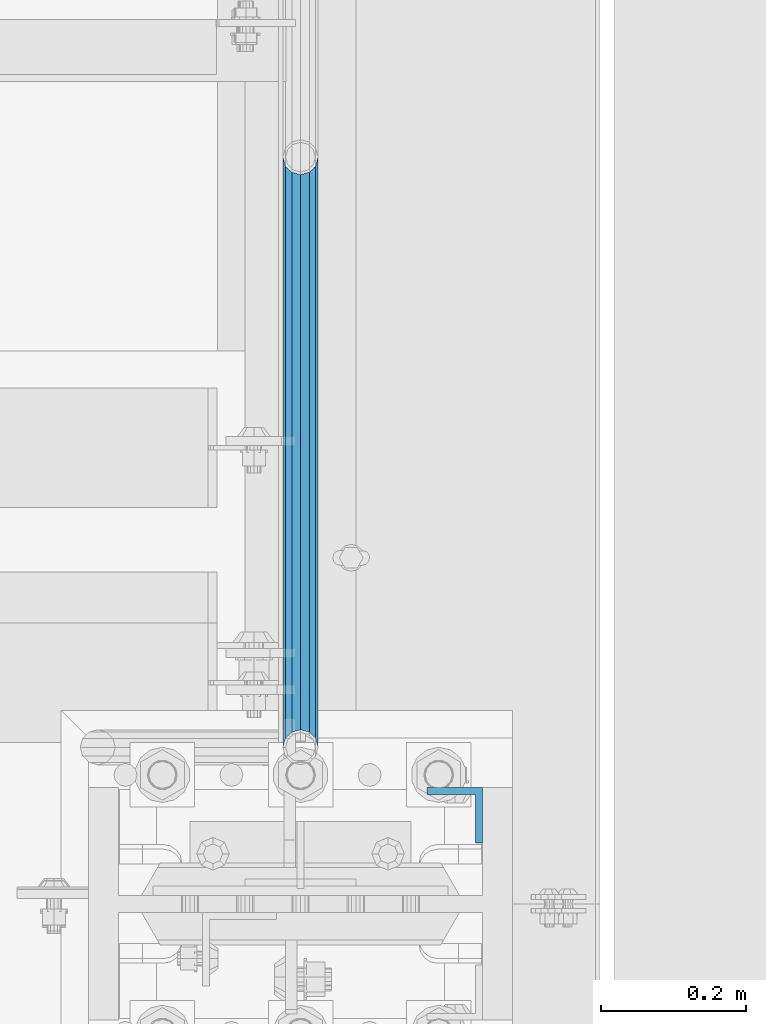
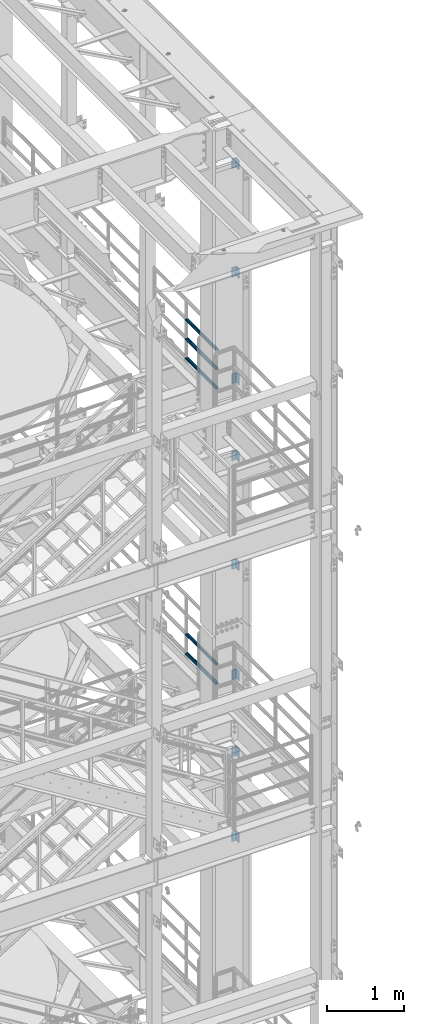
# One storey, part 1218 of 1876: 13 beams, 4 elements without a shape of their own.
"""IFC2X3 building model written with IfcOpenShell, lengths in millimetres."""

from ifc_helpers import new_model, si_unit, frame, origin_with_axes, place, context, subcontext, project, spatial, faceted_brep, material, type_object, element, aggregate, save


model = new_model("IFC2X3")

# Units and contexts
model_context = context("Model", 3, precision=1e-05, world=origin_with_axes())
body_context = subcontext(model_context, "Body", "Model", "MODEL_VIEW")
ifc_project = project(units=[si_unit("LENGTHUNIT", "METRE", prefix="MILLI"), si_unit("AREAUNIT", "SQUARE_METRE"), si_unit("VOLUMEUNIT", "CUBIC_METRE"), si_unit("MASSUNIT", "GRAM", prefix="KILO"), si_unit("TIMEUNIT", "SECOND"), si_unit("PLANEANGLEUNIT", "RADIAN"), si_unit("SOLIDANGLEUNIT", "STERADIAN"), si_unit("THERMODYNAMICTEMPERATUREUNIT", "DEGREE_CELSIUS"), si_unit("LUMINOUSINTENSITYUNIT", "LUMEN")], contexts=[model_context])

# Site, building, storey
site_placement = place(None, origin_with_axes())
site = spatial("IfcSite", under=ifc_project, at=site_placement, CompositionType="ELEMENT")
building_placement = place(site_placement, origin_with_axes())
building = spatial("IfcBuilding", under=site, at=building_placement, Name="Undefined", CompositionType="ELEMENT")
storey_placement = place(building_placement, origin_with_axes())
storey = spatial("IfcBuildingStorey", under=building, at=storey_placement, Name="Undefined", CompositionType="ELEMENT", Elevation=0.0)

# Assembly, beams
assembly_1_placement = place(storey_placement, origin_with_axes())
assembly_1 = element("IfcElementAssembly", 1, at=assembly_1_placement, inside=storey, Name="RAIL", AssemblyPlace="NOTDEFINED", PredefinedType="RIGID_FRAME")
ifc_material_1 = material()
beam_type_1 = type_object("IfcBeamType", Name="PIPE1-1/2SCH40", PredefinedType="NOTDEFINED")
beam_1_placement = place(assembly_1_placement, frame((7620.00000000001, -3542.7031, 18145.125), z_axis=(0.0, 0.0, 1.0), x_axis=(0.0, -1.0, 0.0)))
beam_1 = element("IfcBeam", 2, at=beam_1_placement, type_object=beam_type_1, material=ifc_material_1, Name="RAIL", ObjectType="PIPE1-1/2SCH40", context=body_context, shape_type="Brep", body=[
    faceted_brep([(792.499707006684, -12.0649999999996, 20.8971929933177), (792.499707006684, -12.0650000000314, 15.8661214311469), (792.006278568813, -10.2235000000001, 17.7076214311819), (789.266900000001, -9.09494701772928e-13, 20.4470000000001), (789.266900000001, -9.09494701772928e-13, 24.130000000001), (792.00627856883, 10.2235000000001, 17.7076214311819), (792.499707006684, 12.0649999999678, 15.8661214312124), (792.499707006684, 12.0649999999996, 20.8971929933177), (813.396900000002, 24.1300000000001, 0.0), (801.331900000001, 20.8971929933186, 12.0649999999987), (801.331900000001, 20.8971929933186, -12.0649999999987), (798.142328437896, 17.7076214311801, 10.2235000000001), (800.881707006714, 20.4470000000001, 0.0), (798.142328437896, 17.7076214311801, -10.2235000000001), (792.499707006684, 12.0649999999678, -15.8661214312124), (792.499707006684, 12.0649999999996, -20.8971929933177), (792.00627856883, 10.2235000000001, -17.7076214311819), (789.266900000001, 0.0, -20.4470000000001), (789.266900000001, 0.0, -24.130000000001), (792.499707006684, -12.0650000000314, -15.8661214311469), (792.499707006684, -12.0649999999996, -20.8971929933177), (792.006278568813, -10.2235000000001, -17.7076214311819), (813.396900000002, -24.1300000000319, 0.0), (801.331900000001, -20.8971929933186, -12.0649999999987), (801.331900000001, -20.8971929933186, 12.0649999999987), (798.142328437831, -17.7076214311801, -10.2235000000001), (800.881707006651, -20.4470000000001, 0.0), (798.142328437831, -17.7076214311801, 10.2235000000001), (12.0650000000064, -20.8971929933177, -12.0649999999987), (20.8971929933249, -12.0650000000005, -20.8971929933177), (0.0, 24.1299999999992, 0.0), (12.0650000000064, 20.8971929933177, -12.0649999999987), (12.0650000000064, 20.8971929933177, 12.0649999999987), (20.8971929933249, 12.0650000000005, 20.8971929933177), (24.1300000000064, 0.0, 24.130000000001), (20.8971929933249, 12.0650000000005, -20.8971929933177), (24.1300000000063, 0.0, -24.130000000001), (24.1300000000063, 0.0, -20.4470000000001), (20.8971929933249, -12.0650000000005, -15.8661214311796), (21.3906214311868, -10.2235000000001, -17.7076214311819), (21.3906214311868, 10.2235000000001, -17.7076214311819), (20.8971929933249, 12.0650000000005, -15.8661214311796), (15.2545715621445, 17.7076214311801, -10.2235000000001), (12.5151929933249, 20.4470000000001, 0.0), (15.2545715621445, 17.7076214311801, 10.2235000000001), (20.8971929933249, 12.0650000000005, 15.8661214311796), (21.3906214311868, 10.2235000000001, 17.7076214311819), (24.1300000000064, 0.0, 20.4470000000001), (21.3906214311868, -10.2235000000001, 17.7076214311819), (20.8971929933249, -12.0650000000005, 15.8661214311796), (20.8971929933249, -12.0650000000005, 20.8971929933177), (12.0650000000064, -20.8971929933177, 12.0649999999987), (0.0, -24.1299999999992, 0.0), (15.2545715621445, -17.7076214311801, 10.2235000000001), (12.5151929933249, -20.4470000000001, 0.0), (15.2545715621445, -17.7076214311801, -10.2235000000001)], [[[0, 1, 2, 3, 4]], [[4, 3, 5, 6, 7]], [[8, 9, 10]], [[7, 6, 11, 12, 13, 14, 15, 10, 9]], [[16, 17, 18, 15, 14]], [[19, 20, 18, 17, 21]], [[22, 23, 24]], [[24, 23, 20, 19, 25, 26, 27, 1, 0]], [[28, 29, 20, 23]], [[30, 31, 32]], [[33, 34, 4, 7]], [[32, 33, 7, 9]], [[30, 32, 9, 8]], [[31, 30, 8, 10]], [[35, 31, 10, 15]], [[36, 35, 15, 18]], [[29, 36, 18, 20]], [[37, 36, 29, 38, 39]], [[40, 41, 35, 36, 37]], [[32, 31, 35, 41, 42, 43, 44, 45, 33]], [[33, 45, 46, 47, 34]], [[34, 47, 48, 49, 50]], [[34, 50, 0, 4]], [[50, 51, 24, 0]], [[51, 52, 22, 24]], [[52, 28, 23, 22]], [[51, 28, 52]], [[50, 49, 53, 54, 55, 38, 29, 28, 51]], [[55, 54, 26, 25]], [[21, 39, 38, 55, 25, 19]], [[37, 39, 21, 17]], [[40, 37, 17, 16]], [[42, 41, 40, 16, 14, 13]], [[43, 42, 13, 12]], [[44, 43, 12, 11]], [[5, 46, 45, 44, 11, 6]], [[47, 46, 5, 3]], [[48, 47, 3, 2]], [[53, 49, 48, 2, 1, 27]], [[54, 53, 27, 26]]]),
])
beam_2_placement = place(assembly_1_placement, frame((7620.00000000001, -4356.1, 18449.925000036), z_axis=(0.0, 0.0, -1.0), x_axis=(0.0, 1.0, 0.0)))
beam_2 = element("IfcBeam", 3, at=beam_2_placement, type_object=beam_type_1, material=ifc_material_1, Name="RAIL", ObjectType="PIPE1-1/2SCH40", context=body_context, shape_type="Brep", body=[
    faceted_brep([(0.0, 24.1299999999992, 0.0), (12.0650000000064, 20.8971929933177, -12.0649999999987), (12.0650000000064, 20.8971929933177, 12.0649999999987), (12.0650000000064, -20.8971929933177, 12.0649999999987), (12.0650000000064, -20.8971929933177, -12.0649999999987), (0.0, -24.1299999999992, 0.0), (20.8971929933249, -12.0650000000005, 20.8971929933177), (20.8971929933249, -12.0650000000005, 15.8661214311796), (15.2545715621445, -17.7076214311801, 10.2235000000001), (12.5151929933249, -20.4470000000001, 0.0), (15.2545715621445, -17.7076214311801, -10.2235000000001), (20.8971929933249, -12.0650000000005, -15.8661214311796), (20.8971929933249, -12.0650000000005, -20.8971929933177), (24.1300000000063, 0.0, -20.4470000000001), (24.1300000000063, 0.0, -24.130000000001), (21.3906214311868, -10.2235000000001, -17.7076214311819), (21.3906214311868, 10.2235000000001, -17.7076214311819), (20.8971929933249, 12.0650000000005, -15.8661214311796), (20.8971929933249, 12.0650000000005, -20.8971929933177), (15.2545715621445, 17.7076214311801, -10.2235000000001), (12.5151929933249, 20.4470000000001, 0.0), (15.2545715621445, 17.7076214311801, 10.2235000000001), (20.8971929933249, 12.0650000000005, 15.8661214311796), (20.8971929933249, 12.0650000000005, 20.8971929933177), (21.3906214311868, 10.2235000000001, 17.7076214311819), (24.1300000000064, 0.0, 20.4470000000001), (24.1300000000064, 0.0, 24.130000000001), (21.3906214311868, -10.2235000000001, 17.7076214311819), (813.396900000002, 24.1300000000001, 0.0), (801.331900000001, 20.8971929933186, -12.0649999999987), (792.499707006684, 12.0649999999996, -20.8971929933177), (813.396900000002, -24.1300000000319, 0.0), (801.331900000001, -20.8971929933186, -12.0649999999987), (801.331900000001, -20.8971929933186, 12.0649999999987), (792.499707006684, -12.0649999999996, 20.8971929933177), (792.499707006684, -12.0649999999996, -20.8971929933177), (789.266900000001, 0.0, -24.130000000001), (792.00627856883, 10.2235000000001, -17.7076214311819), (789.266900000001, 0.0, -20.4470000000001), (792.499707006684, 12.0649999999678, -15.8661214312124), (792.499707006684, -12.0650000000314, -15.8661214311469), (792.006278568813, -10.2235000000001, -17.7076214311819), (798.142328437831, -17.7076214311801, -10.2235000000001), (800.881707006651, -20.4470000000001, 0.0), (798.142328437831, -17.7076214311801, 10.2235000000001), (792.499707006684, -12.0650000000314, 15.8661214311469), (792.006278568813, -10.2235000000001, 17.7076214311819), (789.266900000001, -9.09494701772928e-13, 20.4470000000001), (789.266900000001, -9.09494701772928e-13, 24.130000000001), (792.499707006684, 12.0649999999996, 20.8971929933177), (801.331900000001, 20.8971929933186, 12.0649999999987), (792.499707006684, 12.0649999999678, 15.8661214312124), (798.142328437896, 17.7076214311801, 10.2235000000001), (800.881707006714, 20.4470000000001, 0.0), (798.142328437896, 17.7076214311801, -10.2235000000001), (792.00627856883, 10.2235000000001, 17.7076214311819)], [[[0, 1, 2]], [[3, 4, 5]], [[6, 7, 8, 9, 10, 11, 12, 4, 3]], [[13, 14, 12, 11, 15]], [[16, 17, 18, 14, 13]], [[2, 1, 18, 17, 19, 20, 21, 22, 23]], [[23, 22, 24, 25, 26]], [[26, 25, 27, 7, 6]], [[1, 0, 28, 29]], [[18, 1, 29, 30]], [[31, 32, 33]], [[6, 3, 33, 34]], [[3, 5, 31, 33]], [[5, 4, 32, 31]], [[4, 12, 35, 32]], [[12, 14, 36, 35]], [[14, 18, 30, 36]], [[37, 38, 36, 30, 39]], [[40, 35, 36, 38, 41]], [[33, 32, 35, 40, 42, 43, 44, 45, 34]], [[34, 45, 46, 47, 48]], [[26, 6, 34, 48]], [[2, 23, 49, 50]], [[23, 26, 48, 49]], [[0, 2, 50, 28]], [[28, 50, 29]], [[49, 51, 52, 53, 54, 39, 30, 29, 50]], [[48, 47, 55, 51, 49]], [[25, 24, 55, 47]], [[55, 24, 22, 21, 52, 51]], [[21, 20, 53, 52]], [[20, 19, 54, 53]], [[19, 17, 16, 37, 39, 54]], [[16, 13, 38, 37]], [[13, 15, 41, 38]], [[41, 15, 11, 10, 42, 40]], [[10, 9, 43, 42]], [[9, 8, 44, 43]], [[8, 7, 27, 46, 45, 44]], [[27, 25, 47, 46]]]),
])
beam_3_placement = place(assembly_1_placement, frame((7620.00000000001, -4356.1, 18754.7250000359), z_axis=(0.0, 0.0, -1.0), x_axis=(0.0, 1.0, 0.0)))
beam_3 = element("IfcBeam", 4, at=beam_3_placement, type_object=beam_type_1, material=ifc_material_1, Name="RAIL", ObjectType="PIPE1-1/2SCH40", context=body_context, shape_type="Brep", body=[
    faceted_brep([(0.0, 24.1299999999992, 0.0), (12.0650000000064, 20.8971929933177, -12.0649999999987), (12.0650000000064, 20.8971929933177, 12.0649999999987), (12.0650000000064, -20.8971929933177, 12.0649999999987), (12.0650000000064, -20.8971929933177, -12.0649999999987), (0.0, -24.1299999999992, 0.0), (20.8971929933249, -12.0650000000005, 20.8971929933177), (20.8971929933249, -12.0650000000005, 15.8661214311796), (15.2545715621445, -17.7076214311801, 10.2235000000001), (12.5151929933249, -20.4470000000001, 0.0), (15.2545715621445, -17.7076214311801, -10.2235000000001), (20.8971929933249, -12.0650000000005, -15.8661214311796), (20.8971929933249, -12.0650000000005, -20.8971929933177), (24.1300000000063, 0.0, -20.4470000000001), (24.1300000000063, 0.0, -24.130000000001), (21.3906214311868, -10.2235000000001, -17.7076214311819), (21.3906214311868, 10.2235000000001, -17.7076214311819), (20.8971929933249, 12.0650000000005, -15.8661214311796), (20.8971929933249, 12.0650000000005, -20.8971929933177), (15.2545715621445, 17.7076214311801, -10.2235000000001), (12.5151929933249, 20.4470000000001, 0.0), (15.2545715621445, 17.7076214311801, 10.2235000000001), (20.8971929933249, 12.0650000000005, 15.8661214311796), (20.8971929933249, 12.0650000000005, 20.8971929933177), (21.3906214311868, 10.2235000000001, 17.7076214311819), (24.1300000000064, 0.0, 20.4470000000001), (24.1300000000064, 0.0, 24.130000000001), (21.3906214311868, -10.2235000000001, 17.7076214311819), (813.396900000002, 24.1300000000001, 0.0), (801.331900000001, 20.8971929933186, -12.0649999999987), (792.499707006684, 12.0649999999996, -20.8971929933177), (813.396900000002, -24.1300000000319, 0.0), (801.331900000001, -20.8971929933186, -12.0649999999987), (801.331900000001, -20.8971929933186, 12.0649999999987), (792.499707006684, -12.0649999999996, 20.8971929933177), (792.499707006684, -12.0649999999996, -20.8971929933177), (789.266900000001, 0.0, -24.130000000001), (792.00627856883, 10.2235000000001, -17.7076214311819), (789.266900000001, 0.0, -20.4470000000001), (792.499707006684, 12.0649999999678, -15.8661214312124), (792.499707006684, -12.0650000000314, -15.8661214311469), (792.006278568813, -10.2235000000001, -17.7076214311819), (798.142328437831, -17.7076214311801, -10.2235000000001), (800.881707006651, -20.4470000000001, 0.0), (798.142328437831, -17.7076214311801, 10.2235000000001), (792.499707006684, -12.0650000000314, 15.8661214311469), (792.006278568813, -10.2235000000001, 17.7076214311819), (789.266900000001, -9.09494701772928e-13, 20.4470000000001), (789.266900000001, -9.09494701772928e-13, 24.130000000001), (792.499707006684, 12.0649999999996, 20.8971929933177), (801.331900000001, 20.8971929933186, 12.0649999999987), (792.499707006684, 12.0649999999678, 15.8661214312124), (798.142328437896, 17.7076214311801, 10.2235000000001), (800.881707006714, 20.4470000000001, 0.0), (798.142328437896, 17.7076214311801, -10.2235000000001), (792.00627856883, 10.2235000000001, 17.7076214311819)], [[[0, 1, 2]], [[3, 4, 5]], [[6, 7, 8, 9, 10, 11, 12, 4, 3]], [[13, 14, 12, 11, 15]], [[16, 17, 18, 14, 13]], [[2, 1, 18, 17, 19, 20, 21, 22, 23]], [[23, 22, 24, 25, 26]], [[26, 25, 27, 7, 6]], [[1, 0, 28, 29]], [[18, 1, 29, 30]], [[31, 32, 33]], [[6, 3, 33, 34]], [[3, 5, 31, 33]], [[5, 4, 32, 31]], [[4, 12, 35, 32]], [[12, 14, 36, 35]], [[14, 18, 30, 36]], [[37, 38, 36, 30, 39]], [[40, 35, 36, 38, 41]], [[33, 32, 35, 40, 42, 43, 44, 45, 34]], [[34, 45, 46, 47, 48]], [[26, 6, 34, 48]], [[2, 23, 49, 50]], [[23, 26, 48, 49]], [[0, 2, 50, 28]], [[28, 50, 29]], [[49, 51, 52, 53, 54, 39, 30, 29, 50]], [[48, 47, 55, 51, 49]], [[25, 24, 55, 47]], [[55, 24, 22, 21, 52, 51]], [[21, 20, 53, 52]], [[20, 19, 54, 53]], [[19, 17, 16, 37, 39, 54]], [[16, 13, 38, 37]], [[13, 15, 41, 38]], [[41, 15, 11, 10, 42, 40]], [[10, 9, 43, 42]], [[9, 8, 44, 43]], [[8, 7, 27, 46, 45, 44]], [[27, 25, 47, 46]]]),
])
aggregate(assembly_1, [beam_1, beam_2, beam_3])

assembly_2_placement = place(storey_placement, origin_with_axes())
assembly_2 = element("IfcElementAssembly", 5, at=assembly_2_placement, inside=storey, Name="RAIL", AssemblyPlace="NOTDEFINED", PredefinedType="RIGID_FRAME")
beam_4_placement = place(assembly_2_placement, frame((7620.00000000001, -3542.7031, 13471.525), z_axis=(0.0, 0.0, 1.0), x_axis=(0.0, -1.0, 0.0)))
beam_4 = element("IfcBeam", 6, at=beam_4_placement, type_object=beam_type_1, material=ifc_material_1, Name="RAIL", ObjectType="PIPE1-1/2SCH40", context=body_context, shape_type="Brep", body=[
    faceted_brep([(792.499707006684, -12.0649999999996, 20.8971929933177), (792.499707006684, -12.0650000000314, 15.8661214311469), (792.006278568813, -10.2235000000001, 17.7076214311819), (789.266900000001, -9.09494701772928e-13, 20.4470000000001), (789.266900000001, -9.09494701772928e-13, 24.130000000001), (792.00627856883, 10.2235000000001, 17.7076214311819), (792.499707006684, 12.0649999999678, 15.8661214312124), (792.499707006684, 12.0649999999996, 20.8971929933177), (813.396900000002, 24.1300000000001, 0.0), (801.331900000001, 20.8971929933186, 12.0649999999987), (801.331900000001, 20.8971929933186, -12.0649999999987), (798.142328437896, 17.7076214311801, 10.2235000000001), (800.881707006714, 20.4470000000001, 0.0), (798.142328437896, 17.7076214311801, -10.2235000000001), (792.499707006684, 12.0649999999678, -15.8661214312124), (792.499707006684, 12.0649999999996, -20.8971929933177), (792.00627856883, 10.2235000000001, -17.7076214311819), (789.266900000001, 0.0, -20.4470000000001), (789.266900000001, 0.0, -24.130000000001), (792.499707006684, -12.0650000000314, -15.8661214311469), (792.499707006684, -12.0649999999996, -20.8971929933177), (792.006278568813, -10.2235000000001, -17.7076214311819), (813.396900000002, -24.1300000000319, 0.0), (801.331900000001, -20.8971929933186, -12.0649999999987), (801.331900000001, -20.8971929933186, 12.0649999999987), (798.142328437831, -17.7076214311801, -10.2235000000001), (800.881707006651, -20.4470000000001, 0.0), (798.142328437831, -17.7076214311801, 10.2235000000001), (12.0650000000064, -20.8971929933177, -12.0649999999987), (20.8971929933249, -12.0650000000005, -20.8971929933177), (0.0, 24.1299999999992, 0.0), (12.0650000000064, 20.8971929933177, -12.0649999999987), (12.0650000000064, 20.8971929933177, 12.0649999999987), (20.8971929933249, 12.0650000000005, 20.8971929933177), (24.1300000000064, 0.0, 24.130000000001), (20.8971929933249, 12.0650000000005, -20.8971929933177), (24.1300000000063, 0.0, -24.130000000001), (24.1300000000063, 0.0, -20.4470000000001), (20.8971929933249, -12.0650000000005, -15.8661214311796), (21.3906214311868, -10.2235000000001, -17.7076214311819), (21.3906214311868, 10.2235000000001, -17.7076214311819), (20.8971929933249, 12.0650000000005, -15.8661214311796), (15.2545715621445, 17.7076214311801, -10.2235000000001), (12.5151929933249, 20.4470000000001, 0.0), (15.2545715621445, 17.7076214311801, 10.2235000000001), (20.8971929933249, 12.0650000000005, 15.8661214311796), (21.3906214311868, 10.2235000000001, 17.7076214311819), (24.1300000000064, 0.0, 20.4470000000001), (21.3906214311868, -10.2235000000001, 17.7076214311819), (20.8971929933249, -12.0650000000005, 15.8661214311796), (20.8971929933249, -12.0650000000005, 20.8971929933177), (12.0650000000064, -20.8971929933177, 12.0649999999987), (0.0, -24.1299999999992, 0.0), (15.2545715621445, -17.7076214311801, 10.2235000000001), (12.5151929933249, -20.4470000000001, 0.0), (15.2545715621445, -17.7076214311801, -10.2235000000001)], [[[0, 1, 2, 3, 4]], [[4, 3, 5, 6, 7]], [[8, 9, 10]], [[7, 6, 11, 12, 13, 14, 15, 10, 9]], [[16, 17, 18, 15, 14]], [[19, 20, 18, 17, 21]], [[22, 23, 24]], [[24, 23, 20, 19, 25, 26, 27, 1, 0]], [[28, 29, 20, 23]], [[30, 31, 32]], [[33, 34, 4, 7]], [[32, 33, 7, 9]], [[30, 32, 9, 8]], [[31, 30, 8, 10]], [[35, 31, 10, 15]], [[36, 35, 15, 18]], [[29, 36, 18, 20]], [[37, 36, 29, 38, 39]], [[40, 41, 35, 36, 37]], [[32, 31, 35, 41, 42, 43, 44, 45, 33]], [[33, 45, 46, 47, 34]], [[34, 47, 48, 49, 50]], [[34, 50, 0, 4]], [[50, 51, 24, 0]], [[51, 52, 22, 24]], [[52, 28, 23, 22]], [[51, 28, 52]], [[50, 49, 53, 54, 55, 38, 29, 28, 51]], [[55, 54, 26, 25]], [[21, 39, 38, 55, 25, 19]], [[37, 39, 21, 17]], [[40, 37, 17, 16]], [[42, 41, 40, 16, 14, 13]], [[43, 42, 13, 12]], [[44, 43, 12, 11]], [[5, 46, 45, 44, 11, 6]], [[47, 46, 5, 3]], [[48, 47, 3, 2]], [[53, 49, 48, 2, 1, 27]], [[54, 53, 27, 26]]]),
])
beam_5_placement = place(assembly_2_placement, frame((7620.00000000001, -4356.1, 13776.325000036), z_axis=(0.0, 0.0, -1.0), x_axis=(0.0, 1.0, 0.0)))
beam_5 = element("IfcBeam", 7, at=beam_5_placement, type_object=beam_type_1, material=ifc_material_1, Name="RAIL", ObjectType="PIPE1-1/2SCH40", context=body_context, shape_type="Brep", body=[
    faceted_brep([(0.0, 24.1299999999992, 0.0), (12.0650000000064, 20.8971929933177, -12.0649999999987), (12.0650000000064, 20.8971929933177, 12.0649999999987), (12.0650000000064, -20.8971929933177, 12.0649999999987), (12.0650000000064, -20.8971929933177, -12.0649999999987), (0.0, -24.1299999999992, 0.0), (20.8971929933249, -12.0650000000005, 20.8971929933177), (20.8971929933249, -12.0650000000005, 15.8661214311796), (15.2545715621445, -17.7076214311801, 10.2235000000001), (12.5151929933249, -20.4470000000001, 0.0), (15.2545715621445, -17.7076214311801, -10.2235000000001), (20.8971929933249, -12.0650000000005, -15.8661214311796), (20.8971929933249, -12.0650000000005, -20.8971929933177), (24.1300000000063, 0.0, -20.4470000000001), (24.1300000000063, 0.0, -24.130000000001), (21.3906214311868, -10.2235000000001, -17.7076214311819), (21.3906214311868, 10.2235000000001, -17.7076214311819), (20.8971929933249, 12.0650000000005, -15.8661214311796), (20.8971929933249, 12.0650000000005, -20.8971929933177), (15.2545715621445, 17.7076214311801, -10.2235000000001), (12.5151929933249, 20.4470000000001, 0.0), (15.2545715621445, 17.7076214311801, 10.2235000000001), (20.8971929933249, 12.0650000000005, 15.8661214311796), (20.8971929933249, 12.0650000000005, 20.8971929933177), (21.3906214311868, 10.2235000000001, 17.7076214311819), (24.1300000000064, 0.0, 20.4470000000001), (24.1300000000064, 0.0, 24.130000000001), (21.3906214311868, -10.2235000000001, 17.7076214311819), (813.396900000002, 24.1300000000001, 0.0), (801.331900000001, 20.8971929933186, -12.0649999999987), (792.499707006684, 12.0649999999996, -20.8971929933177), (813.396900000002, -24.1300000000319, 0.0), (801.331900000001, -20.8971929933186, -12.0649999999987), (801.331900000001, -20.8971929933186, 12.0649999999987), (792.499707006684, -12.0649999999996, 20.8971929933177), (792.499707006684, -12.0649999999996, -20.8971929933177), (789.266900000001, 0.0, -24.130000000001), (792.00627856883, 10.2235000000001, -17.7076214311819), (789.266900000001, 0.0, -20.4470000000001), (792.499707006684, 12.0649999999678, -15.8661214312124), (792.499707006684, -12.0650000000314, -15.8661214311469), (792.006278568813, -10.2235000000001, -17.7076214311819), (798.142328437831, -17.7076214311801, -10.2235000000001), (800.881707006651, -20.4470000000001, 0.0), (798.142328437831, -17.7076214311801, 10.2235000000001), (792.499707006684, -12.0650000000314, 15.8661214311469), (792.006278568813, -10.2235000000001, 17.7076214311819), (789.266900000001, -9.09494701772928e-13, 20.4470000000001), (789.266900000001, -9.09494701772928e-13, 24.130000000001), (792.499707006684, 12.0649999999996, 20.8971929933177), (801.331900000001, 20.8971929933186, 12.0649999999987), (792.499707006684, 12.0649999999678, 15.8661214312124), (798.142328437896, 17.7076214311801, 10.2235000000001), (800.881707006714, 20.4470000000001, 0.0), (798.142328437896, 17.7076214311801, -10.2235000000001), (792.00627856883, 10.2235000000001, 17.7076214311819)], [[[0, 1, 2]], [[3, 4, 5]], [[6, 7, 8, 9, 10, 11, 12, 4, 3]], [[13, 14, 12, 11, 15]], [[16, 17, 18, 14, 13]], [[2, 1, 18, 17, 19, 20, 21, 22, 23]], [[23, 22, 24, 25, 26]], [[26, 25, 27, 7, 6]], [[1, 0, 28, 29]], [[18, 1, 29, 30]], [[31, 32, 33]], [[6, 3, 33, 34]], [[3, 5, 31, 33]], [[5, 4, 32, 31]], [[4, 12, 35, 32]], [[12, 14, 36, 35]], [[14, 18, 30, 36]], [[37, 38, 36, 30, 39]], [[40, 35, 36, 38, 41]], [[33, 32, 35, 40, 42, 43, 44, 45, 34]], [[34, 45, 46, 47, 48]], [[26, 6, 34, 48]], [[2, 23, 49, 50]], [[23, 26, 48, 49]], [[0, 2, 50, 28]], [[28, 50, 29]], [[49, 51, 52, 53, 54, 39, 30, 29, 50]], [[48, 47, 55, 51, 49]], [[25, 24, 55, 47]], [[55, 24, 22, 21, 52, 51]], [[21, 20, 53, 52]], [[20, 19, 54, 53]], [[19, 17, 16, 37, 39, 54]], [[16, 13, 38, 37]], [[13, 15, 41, 38]], [[41, 15, 11, 10, 42, 40]], [[10, 9, 43, 42]], [[9, 8, 44, 43]], [[8, 7, 27, 46, 45, 44]], [[27, 25, 47, 46]]]),
])
aggregate(assembly_2, [beam_4, beam_5])

assembly_3_placement = place(storey_placement, origin_with_axes())
assembly_3 = element("IfcElementAssembly", 8, at=assembly_3_placement, inside=storey, Name="COLUMN", AssemblyPlace="NOTDEFINED", PredefinedType="RIGID_FRAME")
ifc_material_2 = material(Name="STEEL/A36")
beam_type_2 = type_object("IfcBeamType", Name="L3X3X3/8", PredefinedType="NOTDEFINED")
beam_6_placement = place(assembly_3_placement, frame((7832.725, -4449.7625, 21755.1), z_axis=(0.0, -1.0, 0.0), x_axis=(0.0, 0.0, -1.0)))
beam_6 = element("IfcBeam", 9, at=beam_6_placement, type_object=beam_type_2, material=ifc_material_2, Name="ANGLE", ObjectType="L3X3X3/8", context=body_context, shape_type="Brep", body=[
    faceted_brep([(0.0, 38.1000000000004, -38.1), (0.0, 38.1000000000004, 38.1), (152.4, 38.1000000000004, 38.1), (152.4, 38.1000000000004, -38.1), (0.0, 28.5749999999998, 38.1), (152.4, 28.5749999999998, 38.1), (0.0, 28.5749999999998, -28.575), (152.4, 28.5749999999998, -28.575), (0.0, -38.1000000000004, -28.575), (152.4, -38.1000000000004, -28.575), (0.0, -38.1000000000004, -38.1), (152.4, -38.1000000000004, -38.1)], [[[0, 1, 2, 3]], [[1, 4, 5, 2]], [[4, 6, 7, 5]], [[6, 8, 9, 7]], [[8, 10, 11, 9]], [[10, 0, 3, 11]], [[5, 7, 9, 11, 3, 2]], [[10, 8, 6, 4, 1, 0]]]),
])
beam_7_placement = place(assembly_3_placement, frame((7832.725, -4449.7625, 20034.25), z_axis=(0.0, -1.0, 0.0), x_axis=(0.0, 0.0, -1.0)))
beam_7 = element("IfcBeam", 10, at=beam_7_placement, type_object=beam_type_2, material=ifc_material_2, Name="ANGLE", ObjectType="L3X3X3/8", context=body_context, shape_type="Brep", body=[
    faceted_brep([(0.0, 38.1000000000004, -38.1), (0.0, 38.1000000000004, 38.1), (152.4, 38.1000000000004, 38.1), (152.4, 38.1000000000004, -38.1), (0.0, 28.5749999999998, 38.1), (152.4, 28.5749999999998, 38.1), (0.0, 28.5749999999998, -28.575), (152.4, 28.5749999999998, -28.575), (0.0, -38.1000000000004, -28.575), (152.4, -38.1000000000004, -28.575), (0.0, -38.1000000000004, -38.1), (152.4, -38.1000000000004, -38.1)], [[[0, 1, 2, 3]], [[1, 4, 5, 2]], [[4, 6, 7, 5]], [[6, 8, 9, 7]], [[8, 10, 11, 9]], [[10, 0, 3, 11]], [[5, 7, 9, 11, 3, 2]], [[10, 8, 6, 4, 1, 0]]]),
])
beam_8_placement = place(assembly_3_placement, frame((7832.725, -4449.7625, 18351.5), z_axis=(0.0, -1.0, 0.0), x_axis=(0.0, 0.0, -1.0)))
beam_8 = element("IfcBeam", 11, at=beam_8_placement, type_object=beam_type_2, material=ifc_material_2, Name="ANGLE", ObjectType="L3X3X3/8", context=body_context, shape_type="Brep", body=[
    faceted_brep([(0.0, 38.1000000000004, -38.1), (0.0, 38.1000000000004, 38.1), (152.4, 38.1000000000004, 38.1), (152.4, 38.1000000000004, -38.1), (0.0, 28.5749999999998, 38.1), (152.4, 28.5749999999998, 38.1), (0.0, 28.5749999999998, -28.575), (152.4, 28.5749999999998, -28.575), (0.0, -38.1000000000004, -28.575), (152.4, -38.1000000000004, -28.575), (0.0, -38.1000000000004, -38.1), (152.4, -38.1000000000004, -38.1)], [[[0, 1, 2, 3]], [[1, 4, 5, 2]], [[4, 6, 7, 5]], [[6, 8, 9, 7]], [[8, 10, 11, 9]], [[10, 0, 3, 11]], [[5, 7, 9, 11, 3, 2]], [[10, 8, 6, 4, 1, 0]]]),
])
beam_9_placement = place(assembly_3_placement, frame((7832.725, -4449.7625, 17132.3), z_axis=(0.0, -1.0, 0.0), x_axis=(0.0, 0.0, -1.0)))
beam_9 = element("IfcBeam", 12, at=beam_9_placement, type_object=beam_type_2, material=ifc_material_2, Name="ANGLE", ObjectType="L3X3X3/8", context=body_context, shape_type="Brep", body=[
    faceted_brep([(0.0, 38.1000000000004, -38.1), (0.0, 38.1000000000004, 38.1), (152.4, 38.1000000000004, 38.1), (152.4, 38.1000000000004, -38.1), (0.0, 28.5749999999998, 38.1), (152.4, 28.5749999999998, 38.1), (0.0, 28.5749999999998, -28.575), (152.4, 28.5749999999998, -28.575), (0.0, -38.1000000000004, -28.575), (152.4, -38.1000000000004, -28.575), (0.0, -38.1000000000004, -38.1), (152.4, -38.1000000000004, -38.1)], [[[0, 1, 2, 3]], [[1, 4, 5, 2]], [[4, 6, 7, 5]], [[6, 8, 9, 7]], [[8, 10, 11, 9]], [[10, 0, 3, 11]], [[5, 7, 9, 11, 3, 2]], [[10, 8, 6, 4, 1, 0]]]),
])
beam_10_placement = place(assembly_3_placement, frame((7832.725, -4449.7625, 15411.45), z_axis=(0.0, -1.0, 0.0), x_axis=(0.0, 0.0, -1.0)))
beam_10 = element("IfcBeam", 13, at=beam_10_placement, type_object=beam_type_2, material=ifc_material_2, Name="ANGLE", ObjectType="L3X3X3/8", context=body_context, shape_type="Brep", body=[
    faceted_brep([(0.0, 38.1000000000004, -38.1), (0.0, 38.1000000000004, 38.1), (152.4, 38.1000000000004, 38.1), (152.4, 38.1000000000004, -38.1), (0.0, 28.5749999999998, 38.1), (152.4, 28.5749999999998, 38.1), (0.0, 28.5749999999998, -28.575), (152.4, 28.5749999999998, -28.575), (0.0, -38.1000000000004, -28.575), (152.4, -38.1000000000004, -28.575), (0.0, -38.1000000000004, -38.1), (152.4, -38.1000000000004, -38.1)], [[[0, 1, 2, 3]], [[1, 4, 5, 2]], [[4, 6, 7, 5]], [[6, 8, 9, 7]], [[8, 10, 11, 9]], [[10, 0, 3, 11]], [[5, 7, 9, 11, 3, 2]], [[10, 8, 6, 4, 1, 0]]]),
])
aggregate(assembly_3, [beam_6, beam_7, beam_8, beam_9, beam_10])

assembly_4_placement = place(storey_placement, origin_with_axes())
assembly_4 = element("IfcElementAssembly", 14, at=assembly_4_placement, inside=storey, Name="COLUMN", AssemblyPlace="NOTDEFINED", PredefinedType="RIGID_FRAME")
beam_11_placement = place(assembly_4_placement, frame((7832.725, -4449.7625, 13665.2), z_axis=(0.0, -1.0, 0.0), x_axis=(0.0, 0.0, -1.0)))
beam_11 = element("IfcBeam", 15, at=beam_11_placement, type_object=beam_type_2, material=ifc_material_2, Name="ANGLE", ObjectType="L3X3X3/8", context=body_context, shape_type="Brep", body=[
    faceted_brep([(0.0, 38.1000000000004, -38.1), (0.0, 38.1000000000004, 38.1), (152.4, 38.1000000000004, 38.1), (152.4, 38.1000000000004, -38.1), (0.0, 28.5749999999998, 38.1), (152.4, 28.5749999999998, 38.1), (0.0, 28.5749999999998, -28.575), (152.4, 28.5749999999998, -28.575), (0.0, -38.1000000000004, -28.575), (152.4, -38.1000000000004, -28.575), (0.0, -38.1000000000004, -38.1), (152.4, -38.1000000000004, -38.1)], [[[0, 1, 2, 3]], [[1, 4, 5, 2]], [[4, 6, 7, 5]], [[6, 8, 9, 7]], [[8, 10, 11, 9]], [[10, 0, 3, 11]], [[5, 7, 9, 11, 3, 2]], [[10, 8, 6, 4, 1, 0]]]),
])
beam_12_placement = place(assembly_4_placement, frame((7832.725, -4449.7625, 12446.0), z_axis=(0.0, -1.0, 0.0), x_axis=(0.0, 0.0, -1.0)))
beam_12 = element("IfcBeam", 16, at=beam_12_placement, type_object=beam_type_2, material=ifc_material_2, Name="ANGLE", ObjectType="L3X3X3/8", context=body_context, shape_type="Brep", body=[
    faceted_brep([(0.0, 38.1000000000004, -38.1), (0.0, 38.1000000000004, 38.1), (152.4, 38.1000000000004, 38.1), (152.4, 38.1000000000004, -38.1), (0.0, 28.5749999999998, 38.1), (152.4, 28.5749999999998, 38.1), (0.0, 28.5749999999998, -28.575), (152.4, 28.5749999999998, -28.575), (0.0, -38.1000000000004, -28.575), (152.4, -38.1000000000004, -28.575), (0.0, -38.1000000000004, -38.1), (152.4, -38.1000000000004, -38.1)], [[[0, 1, 2, 3]], [[1, 4, 5, 2]], [[4, 6, 7, 5]], [[6, 8, 9, 7]], [[8, 10, 11, 9]], [[10, 0, 3, 11]], [[5, 7, 9, 11, 3, 2]], [[10, 8, 6, 4, 1, 0]]]),
])
beam_13_placement = place(assembly_4_placement, frame((7832.725, -4449.7625, 11106.15), z_axis=(0.0, -1.0, 0.0), x_axis=(0.0, 0.0, -1.0)))
beam_13 = element("IfcBeam", 17, at=beam_13_placement, type_object=beam_type_2, material=ifc_material_2, Name="ANGLE", ObjectType="L3X3X3/8", context=body_context, shape_type="Brep", body=[
    faceted_brep([(0.0, 38.1000000000004, -38.1), (0.0, 38.1000000000004, 38.1), (152.4, 38.1000000000004, 38.1), (152.4, 38.1000000000004, -38.1), (0.0, 28.5749999999998, 38.1), (152.4, 28.5749999999998, 38.1), (0.0, 28.5749999999998, -28.575), (152.4, 28.5749999999998, -28.575), (0.0, -38.1000000000004, -28.575), (152.4, -38.1000000000004, -28.575), (0.0, -38.1000000000004, -38.1), (152.4, -38.1000000000004, -38.1)], [[[0, 1, 2, 3]], [[1, 4, 5, 2]], [[4, 6, 7, 5]], [[6, 8, 9, 7]], [[8, 10, 11, 9]], [[10, 0, 3, 11]], [[5, 7, 9, 11, 3, 2]], [[10, 8, 6, 4, 1, 0]]]),
])
aggregate(assembly_4, [beam_11, beam_12, beam_13])

save(model, "model.ifc")
